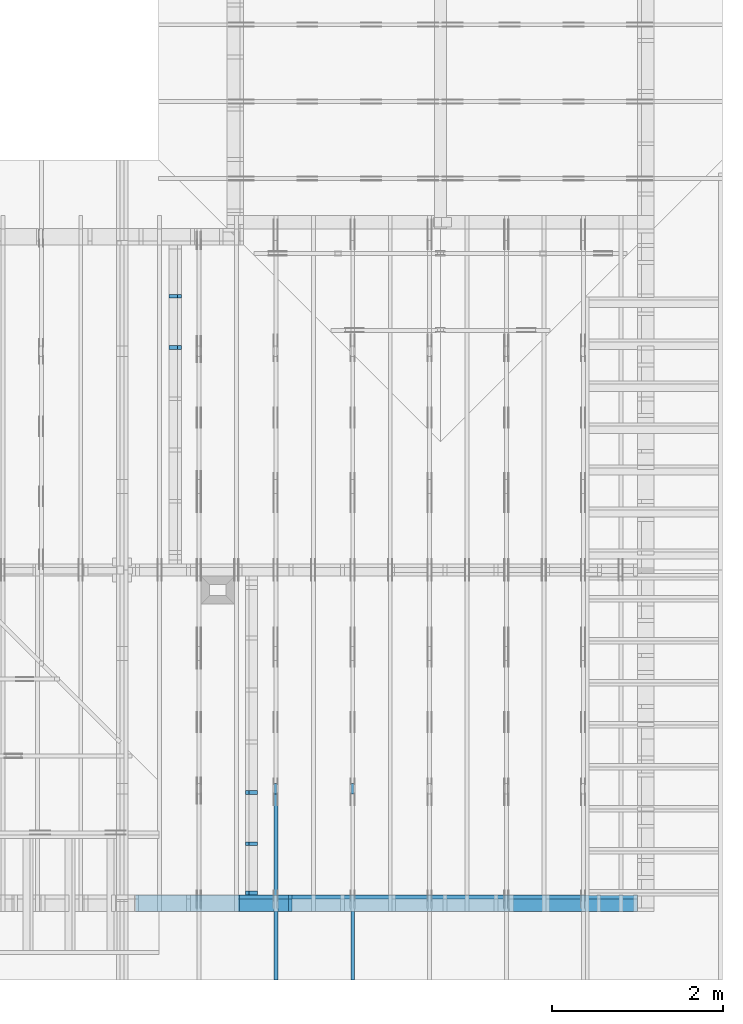
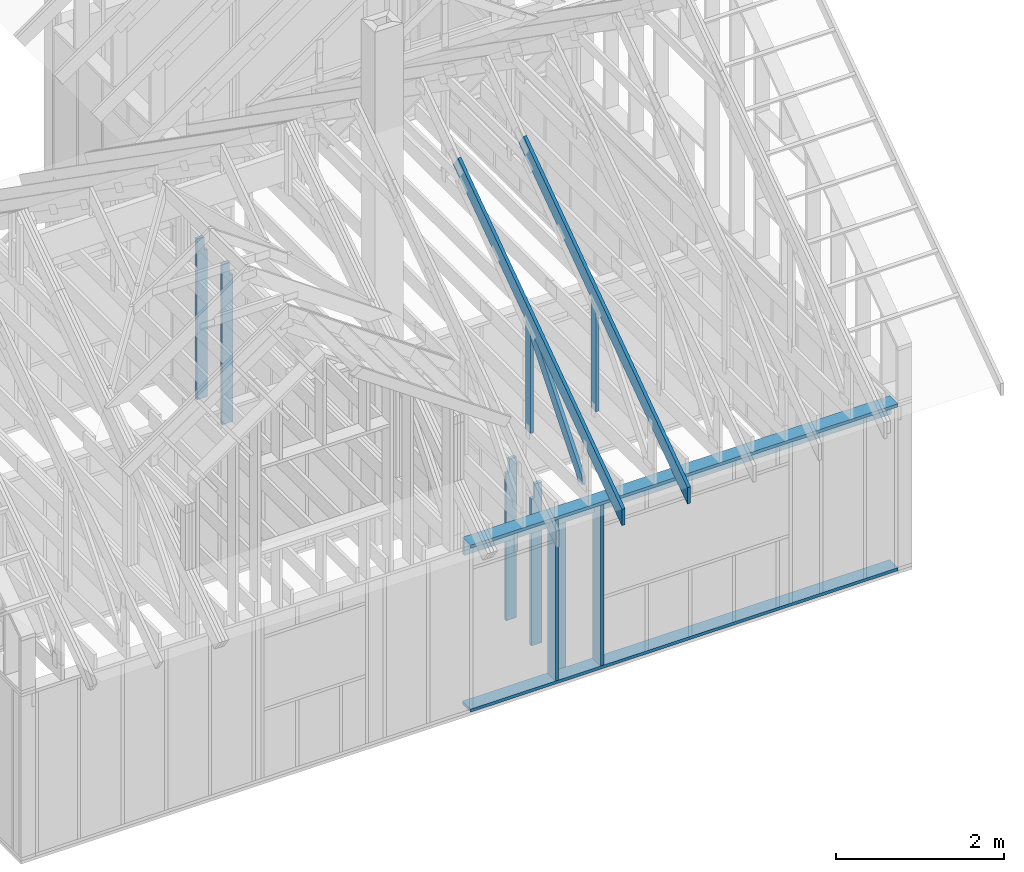
# One storey, part 19 of 70: 15 members, 5 elements without a shape of their own.
"""IFC2X3 building model written with IfcOpenShell, lengths in millimetres."""

from ifc_helpers import new_model, si_unit, frame, origin, origin_with_axes, origin_2d, place, context, project, spatial, faceted_brep, element, aggregate, save


model = new_model("IFC2X3")

# Units and contexts
model_context = context("Model", 3, precision=1e-05, world=origin())
plan_context = context("Plan", 2, precision=1e-05, world=origin_2d())
ifc_project = project(units=[si_unit("LENGTHUNIT", "METRE", prefix="MILLI"), si_unit("AREAUNIT", "SQUARE_METRE"), si_unit("VOLUMEUNIT", "CUBIC_METRE"), si_unit("SOLIDANGLEUNIT", "STERADIAN"), si_unit("PLANEANGLEUNIT", "RADIAN"), si_unit("MASSUNIT", "GRAM"), si_unit("TIMEUNIT", "SECOND"), si_unit("THERMODYNAMICTEMPERATUREUNIT", "DEGREE_CELSIUS"), si_unit("LUMINOUSINTENSITYUNIT", "LUMEN")], contexts=[model_context, plan_context])

# Site, building, storey
site_placement = place(None, origin_with_axes())
site = spatial("IfcSite", under=ifc_project, at=site_placement, CompositionType="ELEMENT")
building_placement = place(site_placement, origin_with_axes())
building = spatial("IfcBuilding", under=site, at=building_placement, Name="Layout 1", CompositionType="ELEMENT")
storey_placement = place(building_placement, origin_with_axes())
storey = spatial("IfcBuildingStorey", under=building, at=storey_placement, Name="Storey 1", CompositionType="ELEMENT", Elevation=0.0)

# Assembly, members
assembly_1_placement = place(storey_placement, frame((-48.55339059325575, 0.0, -2470.0), z_axis=(0.0, -1.0, 6.123031769111886e-17), x_axis=(1.0, 0.0, 0.0)))
assembly_1 = element("IfcElementAssembly", 1, at=assembly_1_placement, inside=storey, Name="VE4", AssemblyPlace="FACTORY", PredefinedType="NOTDEFINED")
member_1_placement = place(assembly_1_placement, frame((5980.000000000002, 2425.0, -195.0), z_axis=(0.0, 0.0, 1.0), x_axis=(1.0, 0.0, 0.0)))
member_1 = element("IfcMember", 2, at=member_1_placement, Name="P3", context=model_context, shape_type="Brep", body=[
    faceted_brep([(5873.553390593253, 45.0, 195.0), (0.0, 45.0, 195.0), (0.0, 0.0, 195.0), (5873.553390593253, 0.0, 195.0), (0.0, 45.0, 0.0), (5873.553390593253, 45.0, 7.192790801635465e-13), (5873.553390593253, 0.0, 7.192790801635465e-13), (0.0, 0.0, 0.0), (0.0, 0.0, 0.0), (1.1939911949768178e-14, -1.462169203776584e-30, 195.0), (1.7450640541968876e-14, 45.0, 195.0), (5.510728592200698e-15, 45.0, -3.3742366240998092e-31), (5873.553390593253, -1.0789186202453198e-12, 6.606252988048455e-29), (5873.553390593253, -1.0669787082955516e-12, 195.0), (2.193253805664876e-30, 1.1939911949768178e-14, 195.0), (0.0, 0.0, 0.0), (5873.553390593253, 45.0, 0.0), (5873.553390593253, 45.0, 195.0), (5873.553390593253, 0.0, 195.0), (5873.553390593253, 0.0, 0.0), (0.0, 45.0, 0.0), (-7.31084601888292e-31, 44.999999999999986, 195.0), (5873.553390593253, 44.99999999999963, 195.0), (5873.553390593253, 44.99999999999964, -2.208810534618833e-29)], [[[0, 1, 2, 3]], [[4, 5, 6, 7]], [[8, 9, 10, 11]], [[12, 13, 14, 15]], [[16, 17, 18, 19]], [[20, 21, 22, 23]]]),
])
member_2_placement = place(assembly_1_placement, frame((11853.553390593255, 90.0, -195.0), z_axis=(0.0, 0.0, 1.0), x_axis=(-1.0, 1.2246063538223773e-16, 0.0)))
member_2 = element("IfcMember", 3, at=member_2_placement, Name="P3", context=model_context, shape_type="Brep", body=[
    faceted_brep([(5873.553390593255, 45.00000000000072, 195.0), (0.0, 45.00000000000072, 195.0), (0.0, 0.0, 195.0), (5873.553390593255, 0.0, 195.0), (0.0, 45.00000000000072, 0.0), (5873.553390593255, 45.00000000000072, 7.192790801635467e-13), (5873.553390593255, 0.0, 7.192790801635467e-13), (0.0, 0.0, 0.0), (0.0, 0.0, 0.0), (1.1939911949768178e-14, -1.462169203776584e-30, 195.0), (1.7450640541968876e-14, 45.0, 195.0), (5.510728592200698e-15, 45.0, -3.3742366240998092e-31), (5873.553390593255, -1.0789186202453202e-12, 1.0956928732419222e-28), (5873.553390593255, -1.066978708295552e-12, 195.0), (2.193253805664876e-30, 1.1939911949768178e-14, 195.0), (0.0, 0.0, 0.0), (5873.553390593255, 45.00000000000072, 0.0), (5873.553390593255, 45.00000000000072, 195.0), (5873.553390593255, 7.105427357601002e-13, 195.0), (5873.553390593255, 7.105427357601002e-13, 0.0), (0.0, 45.0, 0.0), (1.5777218104420236e-30, 44.999999999999986, 195.0), (5873.553390593255, 45.00000000000093, 195.0), (5873.553390593255, 45.000000000000945, 1.4199496293978212e-29)], [[[0, 1, 2, 3]], [[4, 5, 6, 7]], [[8, 9, 10, 11]], [[12, 13, 14, 15]], [[16, 17, 18, 19]], [[20, 21, 22, 23]]]),
])
member_3_placement = place(assembly_1_placement, frame((5980.000000000002, 2230.0, -195.0), z_axis=(0.0, 0.0, 1.0), x_axis=(1.0, 0.0, 0.0)))
member_3 = element("IfcMember", 4, at=member_3_placement, Name="L2", context=model_context, shape_type="Brep", body=[
    faceted_brep([(5873.553390593253, 195.0, 45.0), (0.0, 195.0, 45.0), (0.0, 0.0, 45.0), (5873.553390593253, 0.0, 45.0), (0.0, 195.0, 0.0), (5873.553390593253, 195.0, 7.192790801635465e-13), (5873.553390593253, 0.0, 7.192790801635465e-13), (0.0, 0.0, 0.0), (0.0, 0.0, 0.0), (2.755364296100349e-15, -3.3742366240998092e-31, 45.0), (2.6635188195636705e-14, 195.0, 45.0), (2.3879823899536357e-14, 195.0, -1.462169203776584e-30), (5873.553390593253, -1.0789186202453198e-12, 6.606252988048455e-29), (5873.553390593253, -1.0761632559492195e-12, 45.0), (5.061354936149714e-31, 2.755364296100349e-15, 45.0), (0.0, 0.0, 0.0), (5873.553390593253, 195.0, 0.0), (5873.553390593253, 195.0, 45.0), (5873.553390593253, 0.0, 45.0), (5873.553390593253, 0.0, 0.0), (0.0, 195.0, 0.0), (-1.6871183120499046e-31, 195.0, 45.0), (5873.553390593253, 194.99999999999963, 45.0), (5873.553390593253, 194.99999999999963, -2.208810534618833e-29)], [[[0, 1, 2, 3]], [[4, 5, 6, 7]], [[8, 9, 10, 11]], [[12, 13, 14, 15]], [[16, 17, 18, 19]], [[20, 21, 22, 23]]]),
])
member_4_placement = place(assembly_1_placement, frame((7147.303390595218, 2425.0, -195.0), z_axis=(0.0, 0.0, 1.0), x_axis=(-1.836909530733566e-16, -1.0, 0.0)))
member_4 = element("IfcMember", 5, at=member_4_placement, Name="S11", context=model_context, shape_type="Brep", body=[
    faceted_brep([(0.0, 45.000000000029104, 45.0), (195.00000000186265, 45.000000000029104, 45.00000000000002), (195.00000000186265, 1.4551915228366852e-11, 45.00000000000002), (0.0, 1.4551915228366852e-11, 45.0), (195.00000000186265, 1.3642420526593924e-11, 0.0), (195.00000000186265, 1.3642420526593924e-11, 45.0), (195.00000000186265, 45.000000000028194, 45.0), (195.00000000186265, 45.000000000028194, 0.0), (2.755364296102131e-15, 1.4551915228366852e-11, 45.0), (1.1939911949769961e-14, 1.4551915228366852e-11, 195.00000000000003), (1.7450640541972442e-14, 45.000000000029104, 195.00000000000003), (8.26609288830461e-15, 45.000000000029104, 45.0), (2335.0, 1.4122996852940564e-11, 2.626280839091018e-29), (2335.0, 1.4134936764890332e-11, 195.0), (2.193253805664876e-30, 1.456385514031662e-11, 195.0), (5.061354936149714e-31, 1.4554670592662952e-11, 45.0), (195.00000000186265, 1.4518850856813305e-11, 45.0), (195.00000000186265, 1.4516095492517205e-11, 2.193253805685862e-30), (-1.6871183120499046e-31, 45.000000000028194, 45.0), (-7.31084601888292e-31, 45.00000000002818, 195.0), (2335.0, 45.00000000002804, 195.0), (2335.0, 45.00000000002805, -8.67746995743113e-30), (195.00000000186265, 45.00000000002818, -7.888609052210118e-31), (195.00000000186265, 45.00000000002818, 45.0), (2335.0, 45.00000000001455, 0.0), (2335.0, 45.00000000001455, 195.0), (2335.0, 0.0, 195.0), (2335.0, 0.0, 0.0), (2335.0, 45.00000000001455, 195.0), (0.0, 45.00000000001455, 195.0), (0.0, 1.4551915228366852e-11, 195.0), (2335.0, 1.4551915228366852e-11, 195.0), (195.00000000186265, 45.000000000028194, 2.3879823899764457e-14), (2335.0, 45.000000000028194, 2.859455836175251e-13), (2335.0, 0.0, 2.859455836175251e-13), (195.00000000186265, 0.0, 2.3879823899764457e-14)], [[[0, 1, 2, 3]], [[4, 5, 6, 7]], [[8, 9, 10, 11]], [[12, 13, 14, 15, 16, 17]], [[18, 19, 20, 21, 22, 23]], [[24, 25, 26, 27]], [[28, 29, 30, 31]], [[32, 33, 34, 35]]]),
])
member_5_placement = place(assembly_1_placement, frame((7767.5000000036525, 2425.0, -195.00000000000003), z_axis=(0.0, 0.0, 1.0), x_axis=(-1.836909530733566e-16, -1.0, 0.0)))
member_5 = element("IfcMember", 6, at=member_5_placement, Name="S11", context=model_context, shape_type="Brep", body=[
    faceted_brep([(0.0, 44.99999999998545, 45.00000000000003), (195.00000000186265, 44.99999999998545, 45.00000000000005), (195.00000000186265, 0.0, 45.00000000000005), (0.0, 0.0, 45.00000000000003), (195.00000000186265, -2.1311460639909362e-46, 2.842170943040401e-14), (195.00000000186265, -3.3742366240998114e-31, 45.00000000000003), (195.00000000186265, 44.99999999998636, 45.00000000000003), (195.00000000186265, 44.99999999998636, 2.842170943040401e-14), (2.7553642961003504e-15, -3.3742366240998114e-31, 45.00000000000003), (1.193991194976818e-14, -1.4621692037765842e-30, 195.00000000000003), (1.7450640541967096e-14, 44.99999999998545, 195.00000000000006), (8.266092888299267e-15, 44.99999999998545, 45.00000000000003), (2335.0, -4.2891837542628763e-13, 2.842170943040403e-14), (2335.0, -4.1697846347651946e-13, 195.00000000000003), (2.1932538056648764e-30, 1.193991194976818e-14, 195.00000000000003), (5.061354936149717e-31, 2.7553642961003504e-15, 45.00000000000003), (195.00000000186265, -3.306437155354634e-14, 45.00000000000003), (195.00000000186265, -3.5819735849646686e-14, 2.842170943040401e-14), (-1.6871183120499057e-31, 44.99999999998636, 45.00000000000003), (-7.310846018882921e-31, 44.99999999998634, 195.00000000000003), (2335.0, 44.9999999999862, 195.00000000000003), (2335.0, 44.999999999986215, 2.8421709430403998e-14), (195.00000000186265, 44.99999999998634, 2.8421709430404004e-14), (195.00000000186265, 44.99999999998634, 45.00000000000003), (2335.0, 45.0, 0.0), (2335.0, 45.0, 195.00000000000003), (2335.0, 0.0, 195.00000000000003), (2335.0, 0.0, 0.0), (2335.0, 45.0, 195.00000000000003), (0.0, 45.0, 195.00000000000003), (0.0, 0.0, 195.00000000000003), (2335.0, 0.0, 195.00000000000003), (195.00000000186265, 44.99999999998636, 5.2301533330168465e-14), (2335.0, 44.99999999998636, 3.143672930479291e-13), (2335.0, 0.0, 3.143672930479291e-13), (195.00000000186265, 0.0, 5.2301533330168465e-14)], [[[0, 1, 2, 3]], [[4, 5, 6, 7]], [[8, 9, 10, 11]], [[12, 13, 14, 15, 16, 17]], [[18, 19, 20, 21, 22, 23]], [[24, 25, 26, 27]], [[28, 29, 30, 31]], [[32, 33, 34, 35]]]),
])
aggregate(assembly_1, [member_1, member_2, member_3, member_4, member_5])

assembly_2_placement = place(storey_placement, frame((8450.0, 8000.0, -9.081170196248781e-13), z_axis=(-1.0, 1.836909530733566e-16, 6.123031769111886e-17), x_axis=(-1.836909530733566e-16, -1.0, 0.0)))
assembly_2 = element("IfcElementAssembly", 7, at=assembly_2_placement, inside=storey, Name="T3", AssemblyPlace="FACTORY", PredefinedType="TRUSS")
member_6_placement = place(assembly_2_placement, frame((4782.309641269037, 3015.0000000009313, -45.00000000000001), z_axis=(0.0, 0.0, 1.0), x_axis=(0.8191520442889916, -0.5735764363510465, 0.0)))
member_6 = element("IfcMember", 8, at=member_6_placement, Name="T8", context=model_context, shape_type="Brep", body=[
    faceted_brep([(4768.153825500145, 194.99999999946158, 45.0), (1.6370904631912708e-10, 194.99999999946158, 45.0), (0.0, 0.0, 45.0), (4904.694295450095, 0.0, 45.0), (1.6370904631912708e-10, 194.99999999946158, 2.004791383006049e-26), (4768.153825500145, 194.99999999946158, 5.839111470709952e-13), (4904.694295450095, 0.0, 6.006319797764554e-13), (0.0, 0.0, 0.0), (2.5849394142282115e-26, -2.1699301500556333e-38, -1.582766615454881e-42), (2.7553642961261982e-15, -2.3129934990511945e-27, 45.0), (1.6369571347777126e-10, 194.99999999920783, 45.0), (1.6369295811347516e-10, 194.99999999920783, 9.850859431479521e-31), (4904.694295450095, 8.093603669211209e-10, 5.505686690999094e-30), (4904.694295450095, 8.09363122285417e-10, 45.0), (-4.546833142611764e-28, 2.755364296100349e-15, 45.0), (0.0, 0.0, 0.0), (4768.153825500146, 194.99999999946203, 5.048709793414476e-29), (4768.153825500146, 194.99999999946203, 45.0), (4904.6942954500955, 8.094502845779061e-10, 45.0), (4904.6942954500955, 8.094502845779061e-10, 5.048709793414476e-29), (1.6370904631912708e-10, 194.99999999920783, 0.0), (1.6370904631912708e-10, 194.99999999920783, 45.0), (4768.153825500145, 194.99999999946164, 45.0), (4768.153825500145, 194.99999999946164, 3.1554436208840472e-30)], [[[0, 1, 2, 3]], [[4, 5, 6, 7]], [[8, 9, 10, 11]], [[12, 13, 14, 15]], [[16, 17, 18, 19]], [[20, 21, 22, 23]]]),
])
member_7_placement = place(assembly_2_placement, frame((6619.999999999389, 220.0, -45.0), z_axis=(0.0, 0.0, 1.0), x_axis=(6.123031769111886e-17, 1.0, 0.0)))
member_7 = element("IfcMember", 9, at=member_7_placement, Name="R1", context=model_context, shape_type="Brep", body=[
    faceted_brep([(1592.2602625068248, 120.0, 45.0), (0.0, 120.0, 45.0), (0.0, 1.4551915228366852e-11, 45.0), (1508.235357921585, 1.4551915228366852e-11, 45.0), (0.0, 120.0, 0.0), (1592.2602625068248, 120.0, 1.949892034404744e-13), (1508.235357921585, 1.4551915228366852e-11, 1.8469946023703405e-13), (0.0, 1.4551915228366852e-11, 0.0), (1.7820367848942657e-27, 1.4551915228366852e-11, -1.0911467847633593e-43), (2.755364296102131e-15, 1.4551915228366852e-11, 45.0), (1.7450640541968876e-14, 120.0, 45.0), (1.4695276245868527e-14, 120.0, -8.997964330932825e-31), (1508.235357921585, -4.605370260698061e-13, 2.81988284147774e-29), (1508.235357921585, -4.577816617737058e-13, 45.0), (2.7425941661909085e-29, 1.4554670592662952e-11, 45.0), (0.0, 1.4551915228366852e-11, 0.0), (1592.260262506825, 120.00000000000011, 1.262177448353619e-29), (1592.260262506825, 120.00000000000011, 45.0), (1508.2353579215853, 0.0, 45.0), (1508.2353579215853, 0.0, 1.262177448353619e-29), (0.0, 120.0, 0.0), (-1.6871183120499046e-31, 120.0, 45.0), (1592.2602625068248, 119.9999999999999, 45.0), (1592.2602625068248, 119.9999999999999, -6.310887241768095e-30)], [[[0, 1, 2, 3]], [[4, 5, 6, 7]], [[8, 9, 10, 11]], [[12, 13, 14, 15]], [[16, 17, 18, 19]], [[20, 21, 22, 23]]]),
])
aggregate(assembly_2, [member_6, member_7])

assembly_3_placement = place(storey_placement, frame((7550.000000000001, 8000.0, -9.081170196248781e-13), z_axis=(-1.0, 1.836909530733566e-16, 6.123031769111886e-17), x_axis=(-1.836909530733566e-16, -1.0, 0.0)))
assembly_3 = element("IfcElementAssembly", 10, at=assembly_3_placement, inside=storey, Name="T3", AssemblyPlace="FACTORY", PredefinedType="TRUSS")
member_8_placement = place(assembly_3_placement, frame((4782.309641269037, 3015.0000000009313, -45.00000000000001), z_axis=(0.0, 0.0, 1.0), x_axis=(0.8191520442889916, -0.5735764363510465, 0.0)))
member_8 = element("IfcMember", 11, at=member_8_placement, Name="T8", context=model_context, shape_type="Brep", body=[
    faceted_brep([(4768.153825500145, 194.99999999946158, 45.0), (1.6370904631912708e-10, 194.99999999946158, 45.0), (0.0, 0.0, 45.0), (4904.694295450095, 0.0, 45.0), (1.6370904631912708e-10, 194.99999999946158, 2.004791383006049e-26), (4768.153825500145, 194.99999999946158, 5.839111470709952e-13), (4904.694295450095, 0.0, 6.006319797764554e-13), (0.0, 0.0, 0.0), (2.5849394142282115e-26, -2.1699301500556333e-38, -1.582766615454881e-42), (2.7553642961261982e-15, -2.3129934990511945e-27, 45.0), (1.6369571347777126e-10, 194.99999999920783, 45.0), (1.6369295811347516e-10, 194.99999999920783, 9.850859431479521e-31), (4904.694295450095, 8.093603669211209e-10, 5.505686690999094e-30), (4904.694295450095, 8.09363122285417e-10, 45.0), (-4.546833142611764e-28, 2.755364296100349e-15, 45.0), (0.0, 0.0, 0.0), (4768.153825500146, 194.99999999946203, 5.048709793414476e-29), (4768.153825500146, 194.99999999946203, 45.0), (4904.6942954500955, 8.094502845779061e-10, 45.0), (4904.6942954500955, 8.094502845779061e-10, 5.048709793414476e-29), (1.6370904631912708e-10, 194.99999999920783, 0.0), (1.6370904631912708e-10, 194.99999999920783, 45.0), (4768.153825500145, 194.99999999946164, 45.0), (4768.153825500145, 194.99999999946164, 3.1554436208840472e-30)], [[[0, 1, 2, 3]], [[4, 5, 6, 7]], [[8, 9, 10, 11]], [[12, 13, 14, 15]], [[16, 17, 18, 19]], [[20, 21, 22, 23]]]),
])
member_9_placement = place(assembly_3_placement, frame((6619.999999999389, 220.0, -45.0), z_axis=(0.0, 0.0, 1.0), x_axis=(6.123031769111886e-17, 1.0, 0.0)))
member_9 = element("IfcMember", 12, at=member_9_placement, Name="R1", context=model_context, shape_type="Brep", body=[
    faceted_brep([(1592.2602625068248, 120.0, 45.0), (0.0, 120.0, 45.0), (0.0, 1.4551915228366852e-11, 45.0), (1508.235357921585, 1.4551915228366852e-11, 45.0), (0.0, 120.0, 0.0), (1592.2602625068248, 120.0, 1.949892034404744e-13), (1508.235357921585, 1.4551915228366852e-11, 1.8469946023703405e-13), (0.0, 1.4551915228366852e-11, 0.0), (1.7820367848942657e-27, 1.4551915228366852e-11, -1.0911467847633593e-43), (2.755364296102131e-15, 1.4551915228366852e-11, 45.0), (1.7450640541968876e-14, 120.0, 45.0), (1.4695276245868527e-14, 120.0, -8.997964330932825e-31), (1508.235357921585, -4.605370260698061e-13, 2.81988284147774e-29), (1508.235357921585, -4.577816617737058e-13, 45.0), (2.7425941661909085e-29, 1.4554670592662952e-11, 45.0), (0.0, 1.4551915228366852e-11, 0.0), (1592.260262506825, 120.00000000000011, 1.262177448353619e-29), (1592.260262506825, 120.00000000000011, 45.0), (1508.2353579215853, 0.0, 45.0), (1508.2353579215853, 0.0, 1.262177448353619e-29), (0.0, 120.0, 0.0), (-1.6871183120499046e-31, 120.0, 45.0), (1592.2602625068248, 119.9999999999999, 45.0), (1592.2602625068248, 119.9999999999999, -6.310887241768095e-30)], [[[0, 1, 2, 3]], [[4, 5, 6, 7]], [[8, 9, 10, 11]], [[12, 13, 14, 15]], [[16, 17, 18, 19]], [[20, 21, 22, 23]]]),
])
member_10_placement = place(assembly_3_placement, frame((6563.906131861293, 1682.303582892756, -45.0), z_axis=(0.0, 0.0, 1.0), x_axis=(0.6335417245359889, -0.7737085260432156, 0.0)))
member_10 = element("IfcMember", 13, at=member_10_placement, Name="W6", context=model_context, shape_type="Brep", body=[
    faceted_brep([(1860.8184531590368, 145.00000000000182, 45.0), (258.1329393113165, 145.00000000000182, 45.0), (0.0, 72.4999999999518, 45.0), (88.54013234752438, 0.0, 45.0), (1889.9928508879848, 0.0, 45.0), (1949.3585855061046, 72.4999999999518, 45.0), (258.1329393113165, 145.00000000000182, 3.161112376114843e-14), (1860.8184531590368, 145.00000000000182, 2.2787701010484843e-13), (1949.3585855061046, 72.4999999999518, 2.3871969096889775e-13), (1889.9928508879848, 0.0, 2.314497253876295e-13), (88.54013234752438, 0.0, 1.0842680864105255e-14), (0.0, 72.4999999999518, 0.0), (3.552713678800501e-15, 72.49999999995178, -7.284513455813184e-31), (3.552713678800501e-15, 72.49999999995178, 45.0), (258.13293931131653, 144.9999999999991, 45.0), (258.13293931131653, 144.9999999999991, 8.866211437223917e-31), (88.54013234752439, 0.0, 8.758115402030107e-47), (88.54013234752439, 0.0, 45.0), (0.0, 72.49999999995181, 45.0), (0.0, 72.4999999999518, 8.758115402030107e-47), (1889.9928508879848, 1.2420742274003826e-12, 3.532469951621517e-29), (1889.9928508879848, 1.244829591696483e-12, 45.0), (88.54013234752438, -2.4271270235991317e-14, 45.0), (88.54013234752438, -2.7026634532091666e-14, 1.654849418521736e-30), (1949.3585855061053, 72.49999999999955, 6.310887241768094e-29), (1949.3585855061053, 72.49999999999955, 45.0), (1889.9928508879855, 1.3642420526593924e-12, 45.0), (1889.9928508879855, 1.3642420526593924e-12, 6.310887241768094e-29), (1860.8184531590368, 145.00000000000182, 0.0), (1860.8184531590368, 145.00000000000182, 45.0), (1949.3585855061046, 72.5, 45.0), (1949.3585855061046, 72.5, 0.0), (258.1329393113165, 144.99999999999912, 0.0), (258.1329393113165, 144.9999999999991, 45.0), (1860.8184531590368, 145.00000000000185, 45.0), (1860.8184531590368, 145.00000000000185, 1.5777218104420236e-30)], [[[0, 1, 2, 3, 4, 5]], [[6, 7, 8, 9, 10, 11]], [[12, 13, 14, 15]], [[16, 17, 18, 19]], [[20, 21, 22, 23]], [[24, 25, 26, 27]], [[28, 29, 30, 31]], [[32, 33, 34, 35]]]),
])
aggregate(assembly_3, [member_8, member_9, member_10])

assembly_4_placement = place(storey_placement, frame((6320.15185546875, 7805.0, -2470.0), z_axis=(-1.0, 1.836909530733566e-16, 6.123031769111886e-17), x_axis=(-1.836909530733566e-16, -1.0, 0.0)))
assembly_4 = element("IfcElementAssembly", 14, at=assembly_4_placement, inside=storey, Name="VE7", AssemblyPlace="FACTORY", PredefinedType="NOTDEFINED")
member_11_placement = place(assembly_4_placement, frame((577.500000001819, 2425.0, -145.00000000000003), z_axis=(0.0, 0.0, 1.0), x_axis=(-1.836909530733566e-16, -1.0, 0.0)))
member_11 = element("IfcMember", 15, at=member_11_placement, Name="S42", context=model_context, shape_type="Brep", body=[
    faceted_brep([(0.0, 45.00000000001455, 45.00000000000003), (195.00000000186265, 45.00000000001455, 45.00000000000005), (195.00000000186265, 0.0, 45.00000000000005), (0.0, 0.0, 45.00000000000003), (195.00000000186265, 1.2505552149377763e-12, 2.842170943040401e-14), (195.00000000186265, 1.2505552149377763e-12, 45.00000000000003), (195.00000000186265, 45.0000000000133, 45.00000000000003), (195.00000000186265, 45.0000000000133, 2.842170943040401e-14), (2.7553642961003504e-15, -3.3742366240998114e-31, 45.00000000000003), (8.878396065212235e-15, -1.0872540233210496e-30, 145.0), (1.4389124657414716e-14, 45.00000000001455, 145.00000000000003), (8.26609288830283e-15, 45.00000000001455, 45.00000000000003), (2335.0, -4.2891837542628763e-13, 2.842170943040403e-14), (2335.0, -4.200399793610754e-13, 145.00000000000003), (1.6308810349815748e-30, 8.878396065212237e-15, 145.00000000000003), (5.061354936149717e-31, 2.7553642961003504e-15, 45.00000000000003), (195.00000000186265, -3.306437155354634e-14, 45.00000000000003), (195.00000000186265, -3.5819735849646686e-14, 2.842170943040401e-14), (-1.6871183120499057e-31, 45.0000000000133, 45.00000000000003), (-5.436270116605249e-31, 45.000000000013294, 145.00000000000003), (2335.0, 45.00000000001315, 145.00000000000003), (2335.0, 45.00000000001316, 2.8421709430403992e-14), (195.00000000186265, 45.00000000001329, 2.842170943040401e-14), (195.00000000186265, 45.00000000001329, 45.00000000000003), (2335.0, 45.000000000000455, 0.0), (2335.0, 45.000000000000455, 145.00000000000003), (2335.0, 1.5006662579253316e-11, 145.00000000000003), (2335.0, 1.5006662579253316e-11, 0.0), (2335.0, 45.000000000000455, 145.00000000000003), (0.0, 45.000000000000455, 145.00000000000003), (0.0, 0.0, 145.00000000000003), (2335.0, 0.0, 145.00000000000003), (195.00000000186265, 45.0000000000133, 5.2301533330168465e-14), (2335.0, 45.0000000000133, 3.143672930479291e-13), (2335.0, 1.5006662579253316e-11, 3.143672930479291e-13), (195.00000000186265, 1.5006662579253316e-11, 5.2301533330168465e-14)], [[[0, 1, 2, 3]], [[4, 5, 6, 7]], [[8, 9, 10, 11]], [[12, 13, 14, 15, 16, 17]], [[18, 19, 20, 21, 22, 23]], [[24, 25, 26, 27]], [[28, 29, 30, 31]], [[32, 33, 34, 35]]]),
])
member_12_placement = place(assembly_4_placement, frame((1177.5000000018335, 2425.0, -145.00000000000003), z_axis=(0.0, 0.0, 1.0), x_axis=(-1.836909530733566e-16, -1.0, 0.0)))
member_12 = element("IfcMember", 16, at=member_12_placement, Name="S42", context=model_context, shape_type="Brep", body=[
    faceted_brep([(0.0, 45.0, 45.00000000000003), (195.00000000186265, 45.0, 45.00000000000005), (195.00000000186265, 0.0, 45.00000000000005), (0.0, 0.0, 45.00000000000003), (195.00000000186265, -2.1311460639909362e-46, 2.842170943040401e-14), (195.00000000186265, -3.3742366240998114e-31, 45.00000000000003), (195.00000000186265, 44.99999999999886, 45.00000000000003), (195.00000000186265, 44.99999999999886, 2.842170943040401e-14), (2.7553642961003504e-15, -3.3742366240998114e-31, 45.00000000000003), (8.878396065212235e-15, -1.0872540233210496e-30, 145.0), (1.4389124657412933e-14, 45.0, 145.00000000000003), (8.266092888301048e-15, 45.0, 45.00000000000003), (2335.0, -4.2891837542628763e-13, 2.842170943040403e-14), (2335.0, -4.200399793610754e-13, 145.00000000000003), (1.6308810349815748e-30, 8.878396065212237e-15, 145.00000000000003), (5.061354936149717e-31, 2.7553642961003504e-15, 45.00000000000003), (195.00000000186265, -3.306437155354634e-14, 45.00000000000003), (195.00000000186265, -3.5819735849646686e-14, 2.842170943040401e-14), (-1.6871183120499057e-31, 44.99999999999886, 45.00000000000003), (-5.436270116605249e-31, 44.999999999998856, 145.00000000000003), (2335.0, 44.999999999998714, 145.00000000000003), (2335.0, 44.99999999999872, 2.8421709430403998e-14), (195.00000000186265, 44.99999999999885, 2.842170943040401e-14), (195.00000000186265, 44.99999999999885, 45.00000000000003), (2335.0, 44.9999999999859, 0.0), (2335.0, 44.9999999999859, 145.00000000000003), (2335.0, 4.547473508864641e-13, 145.00000000000003), (2335.0, 4.547473508864641e-13, 0.0), (2335.0, 44.9999999999859, 145.00000000000003), (0.0, 44.9999999999859, 145.00000000000003), (0.0, 0.0, 145.00000000000003), (2335.0, 0.0, 145.00000000000003), (195.00000000186265, 44.99999999999886, 5.2301533330168465e-14), (2335.0, 44.99999999999886, 3.143672930479291e-13), (2335.0, 4.547473508864641e-13, 3.143672930479291e-13), (195.00000000186265, 4.547473508864641e-13, 5.2301533330168465e-14)], [[[0, 1, 2, 3]], [[4, 5, 6, 7]], [[8, 9, 10, 11]], [[12, 13, 14, 15, 16, 17]], [[18, 19, 20, 21, 22, 23]], [[24, 25, 26, 27]], [[28, 29, 30, 31]], [[32, 33, 34, 35]]]),
])
aggregate(assembly_4, [member_11, member_12])

assembly_5_placement = place(storey_placement, frame((7359.197265625001, 195.0, -2470.0), z_axis=(1.0, -6.123031769111886e-17, 6.123031769111886e-17), x_axis=(6.123031769111886e-17, 1.0, 0.0)))
assembly_5 = element("IfcElementAssembly", 17, at=assembly_5_placement, inside=storey, Name="VE10", AssemblyPlace="FACTORY", PredefinedType="NOTDEFINED")
member_13_placement = place(assembly_5_placement, frame((45.0, 90.00000000000045, -145.0), z_axis=(0.0, 0.0, 1.0), x_axis=(6.123031769111886e-17, 1.0, 0.0)))
member_13 = element("IfcMember", 18, at=member_13_placement, Name="SC5", context=model_context, shape_type="Brep", body=[
    faceted_brep([(2139.999999998137, 45.00000000000013, 0.0), (2139.999999998137, 45.00000000000013, 45.0), (2139.999999998137, 1.2789769243681803e-13, 45.0), (2139.999999998137, 1.2789769243681803e-13, 0.0), (2139.999999998137, 45.00000000000013, 45.00000000000026), (2334.9999999999995, 45.00000000000013, 45.000000000000284), (2334.9999999999995, 1.2789769243681803e-13, 45.000000000000284), (2139.999999998137, 1.2789769243681803e-13, 45.00000000000026), (1.2154326714572542e-63, 45.00000000000014, 0.0), (-5.436270116605248e-31, 45.000000000000135, 145.0), (2334.9999999999995, 44.99999999999999, 145.0), (2334.9999999999995, 44.99999999999999, 45.0), (2139.999999998137, 45.00000000000001, 45.0), (2139.999999998137, 45.000000000000014, -7.888609052210118e-30), (0.0, 45.0, 0.0), (2139.999999998137, 45.0, 2.620657597177606e-13), (2139.999999998137, 1.2789769243681803e-13, 2.620657597177606e-13), (0.0, 1.2789769243681803e-13, 0.0), (1.7402702977483063e-30, -2.1311460639909362e-46, 2.842170943040401e-14), (8.878396065212235e-15, -1.0872540233210496e-30, 145.0), (1.4389124657412933e-14, 44.99999999999999, 145.0), (5.510728592200697e-15, 44.99999999999999, -3.3742366240998084e-31), (2334.9999999999995, -2.9826531869336915e-13, 45.0), (2334.9999999999995, -2.9214228692425727e-13, 145.0), (1.6308810349815745e-30, 1.3677608850203027e-13, 145.0), (0.0, 1.2789769243681803e-13, 0.0), (2139.999999998137, -2.652009471398228e-13, 2.4069554585224354e-29), (2139.999999998137, -2.6244558284372247e-13, 45.0), (2334.9999999999995, 45.00000000000014, 45.0), (2334.9999999999995, 45.00000000000014, 145.0), (2334.9999999999995, 1.3500311979441904e-13, 145.0), (2334.9999999999995, 1.3500311979441904e-13, 45.0), (2334.9999999999995, 45.00000000000014, 145.0), (0.0, 45.00000000000014, 145.0), (0.0, 0.0, 145.0), (2334.9999999999995, 0.0, 145.0)], [[[0, 1, 2, 3]], [[4, 5, 6, 7]], [[8, 9, 10, 11, 12, 13]], [[14, 15, 16, 17]], [[18, 19, 20, 21]], [[22, 23, 24, 25, 26, 27]], [[28, 29, 30, 31]], [[32, 33, 34, 35]]]),
])
member_14_placement = place(assembly_5_placement, frame((577.500000001819, 2425.0, -145.00000000000003), z_axis=(0.0, 0.0, 1.0), x_axis=(-1.836909530733566e-16, -1.0, 0.0)))
member_14 = element("IfcMember", 19, at=member_14_placement, Name="S42", context=model_context, shape_type="Brep", body=[
    faceted_brep([(0.0, 45.00000000001455, 45.00000000000003), (195.00000000186265, 45.00000000001455, 45.00000000000005), (195.00000000186265, 0.0, 45.00000000000005), (0.0, 0.0, 45.00000000000003), (195.00000000186265, 1.2505552149377763e-12, 2.842170943040401e-14), (195.00000000186265, 1.2505552149377763e-12, 45.00000000000003), (195.00000000186265, 45.0000000000133, 45.00000000000003), (195.00000000186265, 45.0000000000133, 2.842170943040401e-14), (2.7553642961003504e-15, -3.3742366240998114e-31, 45.00000000000003), (8.878396065212235e-15, -1.0872540233210496e-30, 145.0), (1.4389124657414716e-14, 45.00000000001455, 145.00000000000003), (8.26609288830283e-15, 45.00000000001455, 45.00000000000003), (2335.0, -4.2891837542628763e-13, 2.842170943040403e-14), (2335.0, -4.200399793610754e-13, 145.00000000000003), (1.6308810349815748e-30, 8.878396065212237e-15, 145.00000000000003), (5.061354936149717e-31, 2.7553642961003504e-15, 45.00000000000003), (195.00000000186265, -3.306437155354634e-14, 45.00000000000003), (195.00000000186265, -3.5819735849646686e-14, 2.842170943040401e-14), (-1.6871183120499057e-31, 45.0000000000133, 45.00000000000003), (-5.436270116605249e-31, 45.000000000013294, 145.00000000000003), (2335.0, 45.00000000001315, 145.00000000000003), (2335.0, 45.00000000001316, 2.8421709430403992e-14), (195.00000000186265, 45.00000000001329, 2.842170943040401e-14), (195.00000000186265, 45.00000000001329, 45.00000000000003), (2335.0, 45.000000000000455, 0.0), (2335.0, 45.000000000000455, 145.00000000000003), (2335.0, 1.5006662579253316e-11, 145.00000000000003), (2335.0, 1.5006662579253316e-11, 0.0), (2335.0, 45.000000000000455, 145.00000000000003), (0.0, 45.000000000000455, 145.00000000000003), (0.0, 0.0, 145.00000000000003), (2335.0, 0.0, 145.00000000000003), (195.00000000186265, 45.0000000000133, 5.2301533330168465e-14), (2335.0, 45.0000000000133, 3.143672930479291e-13), (2335.0, 1.5006662579253316e-11, 3.143672930479291e-13), (195.00000000186265, 1.5006662579253316e-11, 5.2301533330168465e-14)], [[[0, 1, 2, 3]], [[4, 5, 6, 7]], [[8, 9, 10, 11]], [[12, 13, 14, 15, 16, 17]], [[18, 19, 20, 21, 22, 23]], [[24, 25, 26, 27]], [[28, 29, 30, 31]], [[32, 33, 34, 35]]]),
])
member_15_placement = place(assembly_5_placement, frame((1177.5000000018335, 2425.0, -145.00000000000003), z_axis=(0.0, 0.0, 1.0), x_axis=(-1.836909530733566e-16, -1.0, 0.0)))
member_15 = element("IfcMember", 20, at=member_15_placement, Name="S42", context=model_context, shape_type="Brep", body=[
    faceted_brep([(0.0, 45.0, 45.00000000000003), (195.00000000186265, 45.0, 45.00000000000005), (195.00000000186265, 0.0, 45.00000000000005), (0.0, 0.0, 45.00000000000003), (195.00000000186265, -2.1311460639909362e-46, 2.842170943040401e-14), (195.00000000186265, -3.3742366240998114e-31, 45.00000000000003), (195.00000000186265, 44.99999999999886, 45.00000000000003), (195.00000000186265, 44.99999999999886, 2.842170943040401e-14), (2.7553642961003504e-15, -3.3742366240998114e-31, 45.00000000000003), (8.878396065212235e-15, -1.0872540233210496e-30, 145.0), (1.4389124657412933e-14, 45.0, 145.00000000000003), (8.266092888301048e-15, 45.0, 45.00000000000003), (2335.0, -4.2891837542628763e-13, 2.842170943040403e-14), (2335.0, -4.200399793610754e-13, 145.00000000000003), (1.6308810349815748e-30, 8.878396065212237e-15, 145.00000000000003), (5.061354936149717e-31, 2.7553642961003504e-15, 45.00000000000003), (195.00000000186265, -3.306437155354634e-14, 45.00000000000003), (195.00000000186265, -3.5819735849646686e-14, 2.842170943040401e-14), (-1.6871183120499057e-31, 44.99999999999886, 45.00000000000003), (-5.436270116605249e-31, 44.999999999998856, 145.00000000000003), (2335.0, 44.999999999998714, 145.00000000000003), (2335.0, 44.99999999999872, 2.8421709430403998e-14), (195.00000000186265, 44.99999999999885, 2.842170943040401e-14), (195.00000000186265, 44.99999999999885, 45.00000000000003), (2335.0, 44.9999999999859, 0.0), (2335.0, 44.9999999999859, 145.00000000000003), (2335.0, 4.547473508864641e-13, 145.00000000000003), (2335.0, 4.547473508864641e-13, 0.0), (2335.0, 44.9999999999859, 145.00000000000003), (0.0, 44.9999999999859, 145.00000000000003), (0.0, 0.0, 145.00000000000003), (2335.0, 0.0, 145.00000000000003), (195.00000000186265, 44.99999999999886, 5.2301533330168465e-14), (2335.0, 44.99999999999886, 3.143672930479291e-13), (2335.0, 4.547473508864641e-13, 3.143672930479291e-13), (195.00000000186265, 4.547473508864641e-13, 5.2301533330168465e-14)], [[[0, 1, 2, 3]], [[4, 5, 6, 7]], [[8, 9, 10, 11]], [[12, 13, 14, 15, 16, 17]], [[18, 19, 20, 21, 22, 23]], [[24, 25, 26, 27]], [[28, 29, 30, 31]], [[32, 33, 34, 35]]]),
])
aggregate(assembly_5, [member_13, member_14, member_15])

save(model, "model.ifc")
